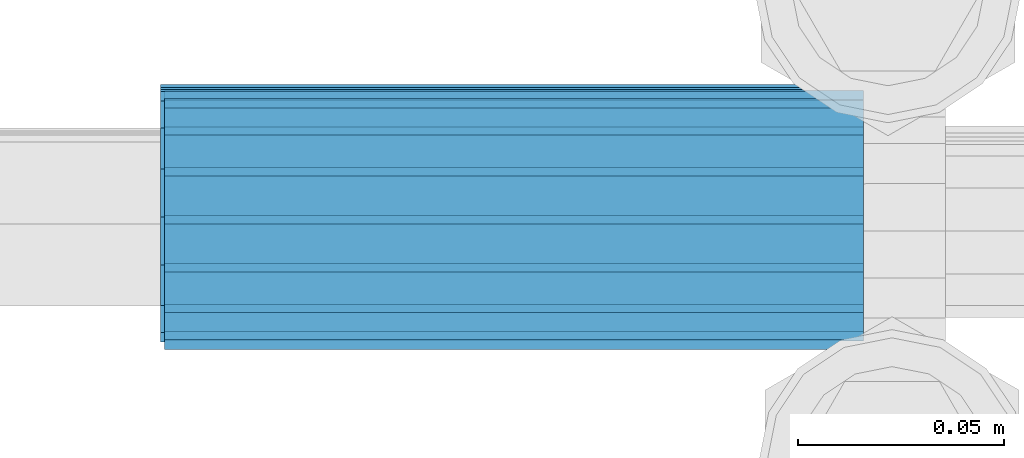
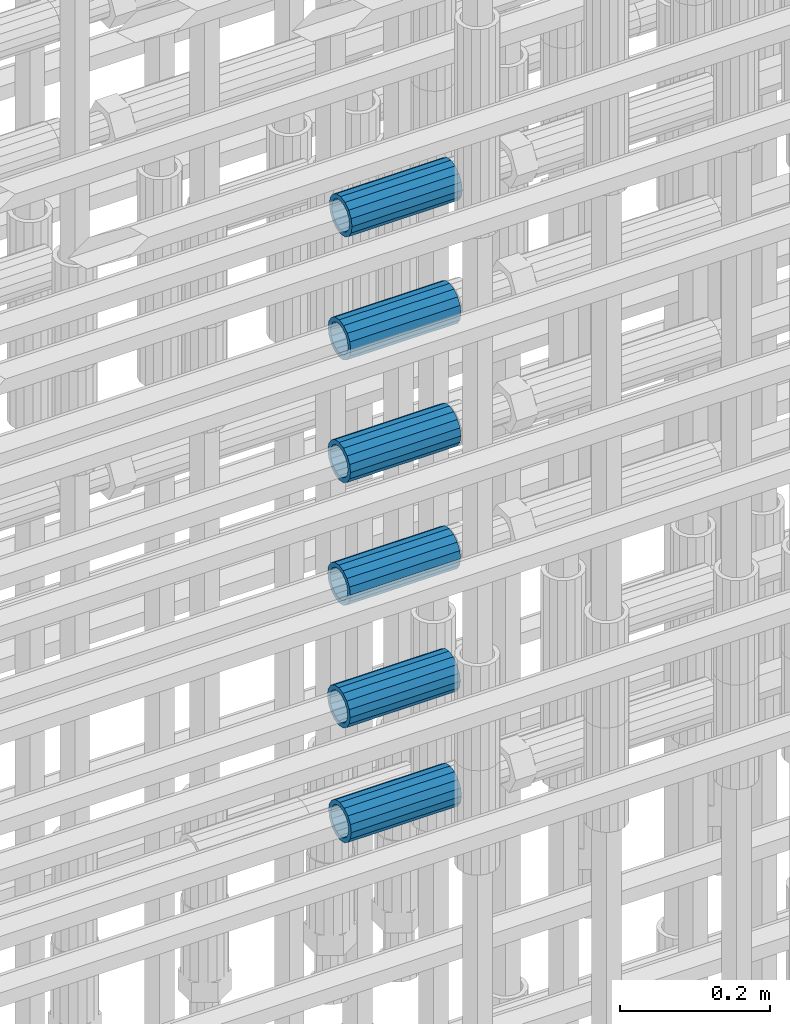
# One storey, part 25 of 119: 6 beams.
"""IFC2X3 building model written with IfcOpenShell, lengths in millimetres."""

import ifcopenshell
import ifcopenshell.guid

model = None  # the IFC model being written
_history = None  # IfcOwnerHistory: only IFC2X3 demands one
_inside = {}  # id of a spatial element -> (the spatial element, [elements in it])
_under = {}  # id of a project, library or spatial element -> (it, [spatial elements below it])
_declared = {}  # id of a project -> (the project, [libraries it declares])
_typed = {}  # id of a type object -> (the type object, [elements of that type])
_made_of = {}  # id of a material, layer set ... -> (it, [elements and type objects made of it])


def new_model(schema):
    """Start an empty IFC model of exactly this schema.

    Asked for "IFC4X3", IfcOpenShell would pick the latest addendum, in which some entities
    have other attributes; the version numbers below select the first issue.
    IFC2X3 requires an IfcOwnerHistory on every rooted entity: one is made here for all.
    """
    global model, _history
    if schema == "IFC4X3":
        model = ifcopenshell.file(schema_version=(4, 3, 0, 0))
    else:
        model = ifcopenshell.file(schema=schema)
    _inside.clear()
    _under.clear()
    _declared.clear()
    _typed.clear()
    _made_of.clear()
    _history = None
    if model.schema == "IFC2X3":
        org = make("IfcOrganization", Name="unknown")
        user = make(
            "IfcPersonAndOrganization",
            ThePerson=make("IfcPerson", FamilyName="unknown"),
            TheOrganization=org,
        )
        app = make(
            "IfcApplication",
            ApplicationDeveloper=org,
            Version="unknown",
            ApplicationFullName="unknown",
            ApplicationIdentifier="unknown",
        )
        _history = make(
            "IfcOwnerHistory",
            OwningUser=user,
            OwningApplication=app,
            ChangeAction="ADDED",
            CreationDate=0,
        )
    return model


def make(cls, **values):
    """One entity of the class cls with the attributes given. An attribute that is None is left unset."""
    return model.create_entity(
        cls, **{name: value for name, value in values.items() if value is not None}
    )


def rooted(cls, **values):
    """An entity with a GlobalId (a new one), such as an element, a storey or a relation."""
    return make(cls, GlobalId=ifcopenshell.guid.new(), OwnerHistory=_history, **values)


def si_unit(unit_type, name, prefix=None):
    """IfcSIUnit, for example si_unit("LENGTHUNIT", "METRE", prefix="MILLI")."""
    return make("IfcSIUnit", UnitType=unit_type, Prefix=prefix, Name=name)


def assignment(units):
    """IfcUnitAssignment: the units of a project."""
    return None if units is None else make("IfcUnitAssignment", Units=units)


def point(xyz):
    """IfcCartesianPoint."""
    return None if xyz is None else make("IfcCartesianPoint", Coordinates=xyz)


def direction(xyz):
    """IfcDirection."""
    return None if xyz is None else make("IfcDirection", DirectionRatios=xyz)


def frame(location, z_axis=None, x_axis=None):
    """IfcAxis2Placement3D, a coordinate frame: its origin and axes. An axis left out is left unset."""
    return make(
        "IfcAxis2Placement3D",
        Location=point(location),
        Axis=direction(z_axis),
        RefDirection=direction(x_axis),
    )


def origin_with_axes():
    """The frame at (0, 0, 0) with the z axis (0, 0, 1) and the x axis (1, 0, 0) written out."""
    return frame((0.0, 0.0, 0.0), z_axis=(0.0, 0.0, 1.0), x_axis=(1.0, 0.0, 0.0))


def place(relative_to, where):
    """IfcLocalPlacement: puts the frame where relative to a parent placement (None: the world)."""
    return make(
        "IfcLocalPlacement", PlacementRelTo=relative_to, RelativePlacement=where
    )


def context(
    kind, dimensions, precision=None, world=None, true_north=None, identifier=None
):
    """IfcGeometricRepresentationContext, for example the 3D "Model" context."""
    return make(
        "IfcGeometricRepresentationContext",
        ContextIdentifier=identifier,
        ContextType=kind,
        CoordinateSpaceDimension=dimensions,
        Precision=precision,
        WorldCoordinateSystem=world,
        TrueNorth=true_north,
    )


def subcontext(parent, identifier, kind, view, scale=None):
    """IfcGeometricRepresentationSubContext, for example "Body" below "Model"."""
    return make(
        "IfcGeometricRepresentationSubContext",
        ContextIdentifier=identifier,
        ContextType=kind,
        ParentContext=parent,
        TargetScale=scale,
        TargetView=view,
    )


def project(units=None, contexts=None):
    """IfcProject with its units and contexts."""
    return rooted(
        "IfcProject",
        Name="project",
        RepresentationContexts=contexts,
        UnitsInContext=assignment(units),
    )


def spatial(cls, under=None, at=None, **own):
    """A site, building, storey or space (cls), placed at a placement, below another one or the project."""
    s = rooted(cls, ObjectPlacement=at, **own)
    if under is not None:
        _under.setdefault(under.id(), (under, []))[1].append(s)
    return s


def faces_of(points, faces, orient=None, outer=None):
    """IfcFace entities. A face is a list of loops; a loop is a list of indices into points, from 0.

    orient and outer hold one flag for each loop. By default every Orientation is true, the
    first loop of a face is its IfcFaceOuterBound and the others are IfcFaceBound.
    """
    made = []
    for i, loops in enumerate(faces):
        bounds = []
        for j, loop in enumerate(loops):
            is_outer = j == 0 if outer is None else outer[i][j]
            bounds.append(
                make(
                    "IfcFaceOuterBound" if is_outer else "IfcFaceBound",
                    Bound=make("IfcPolyLoop", Polygon=[points[k] for k in loop]),
                    Orientation=True if orient is None else orient[i][j],
                )
            )
        made.append(make("IfcFace", Bounds=bounds))
    return made


def faceted_brep(points, faces, orient=None, outer=None, voids=None):
    """IfcFacetedBrep: a solid bounded by flat faces; with voids (closed shells), ...WithVoids."""
    shared = [point(p) for p in points]
    hull = make("IfcClosedShell", CfsFaces=faces_of(shared, faces, orient, outer))
    if voids is None:
        return make("IfcFacetedBrep", Outer=hull)
    return make(
        "IfcFacetedBrepWithVoids",
        Outer=hull,
        Voids=[
            make(cls, CfsFaces=faces_of(shared, fs, o, b)) for cls, fs, o, b in voids
        ],
    )


def shape(context_of_items, identifier, shape_type, items):
    """IfcShapeRepresentation: the items that make up one representation, for example the "Body"."""
    return make(
        "IfcShapeRepresentation",
        ContextOfItems=context_of_items,
        RepresentationIdentifier=identifier,
        RepresentationType=shape_type,
        Items=items,
    )


def material(Name=None, Category=None):
    """IfcMaterial."""
    return make("IfcMaterial", Name=Name, Category=Category)


def made_of(thing, what):
    """Note that an element or type object is made of a material, layer set ...; save() writes the relation."""
    if what is not None:
        _made_of.setdefault(what.id(), (what, []))[1].append(thing)
    return thing


def type_object(cls, material=None, **own):
    """A type object (cls), such as IfcWallType, which elements share."""
    return made_of(rooted(cls, **own), material)


def element(
    cls,
    number,
    at=None,
    inside=None,
    cuts=None,
    type_object=None,
    material=None,
    context=None,
    identifier="Body",
    shape_type=None,
    held_by="IfcProductDefinitionShape",
    body=None,
    shapes=None,
    **own,
):
    """One element of the class cls, such as IfcWall. Its Tag is "e" and its number.

    at: its placement. inside: the storey or other place that contains it. cuts: it is an
    opening in that element (IfcRelVoidsElement). A single representation is given by context,
    identifier, shape_type and body (its items); several are given by shapes. held_by: the class
    of the entity that holds the representations. save() writes the other relations.
    """
    e = rooted(cls, Tag="e%d" % number, ObjectPlacement=at, **own)
    if body is not None:
        shapes = [shape(context, identifier, shape_type, body)]
    if shapes is not None:
        e.Representation = make(held_by, Representations=shapes)
    if inside is not None:
        _inside.setdefault(inside.id(), (inside, []))[1].append(e)
    if cuts is not None:
        rooted(
            "IfcRelVoidsElement", RelatingBuildingElement=cuts, RelatedOpeningElement=e
        )
    if type_object is not None:
        _typed.setdefault(type_object.id(), (type_object, []))[1].append(e)
    return made_of(e, material)


def aggregate(whole, parts):
    """IfcRelAggregates: a whole, such as a stair, and the parts it consists of."""
    return rooted("IfcRelAggregates", RelatingObject=whole, RelatedObjects=parts)


def save(model, path):
    """Write the relations noted so far, then the file.

    IfcRelAggregates (storeys below a building ...), IfcRelContainedInSpatialStructure (elements
    in a storey), IfcRelDefinesByType, IfcRelAssociatesMaterial and IfcRelDeclares: one each for
    every whole, place, type object, material and project.
    """
    for whole, parts in _under.values():
        aggregate(whole, parts)
    for where, things in _inside.values():
        rooted(
            "IfcRelContainedInSpatialStructure",
            RelatedElements=things,
            RelatingStructure=where,
        )
    for kind, things in _typed.values():
        rooted("IfcRelDefinesByType", RelatedObjects=things, RelatingType=kind)
    for what, things in _made_of.values():
        rooted("IfcRelAssociatesMaterial", RelatedObjects=things, RelatingMaterial=what)
    for by, libraries in _declared.values():
        rooted("IfcRelDeclares", RelatingContext=by, RelatedDefinitions=libraries)
    model.write(path)


model = new_model("IFC2X3")

# Units and contexts
model_context = context("Model", 3, precision=1e-05, world=origin_with_axes())
body_context = subcontext(model_context, "Body", "Model", "MODEL_VIEW")
ifc_project = project(units=[si_unit("LENGTHUNIT", "METRE", prefix="MILLI"), si_unit("AREAUNIT", "SQUARE_METRE"), si_unit("VOLUMEUNIT", "CUBIC_METRE"), si_unit("MASSUNIT", "GRAM", prefix="KILO"), si_unit("TIMEUNIT", "SECOND"), si_unit("PLANEANGLEUNIT", "RADIAN"), si_unit("SOLIDANGLEUNIT", "STERADIAN"), si_unit("THERMODYNAMICTEMPERATUREUNIT", "DEGREE_CELSIUS"), si_unit("LUMINOUSINTENSITYUNIT", "LUMEN")], contexts=[model_context])

# Site, building, storey
site_placement = place(None, origin_with_axes())
site = spatial("IfcSite", under=ifc_project, at=site_placement, CompositionType="ELEMENT")
building_placement = place(site_placement, origin_with_axes())
building = spatial("IfcBuilding", under=site, at=building_placement, Name="Undefined", CompositionType="ELEMENT")
storey_placement = place(building_placement, origin_with_axes())
storey = spatial("IfcBuildingStorey", under=building, at=storey_placement, Name="Undefined", CompositionType="ELEMENT", Elevation=0.0)

# Beams
ifc_material = material(Name="STEEL/S275")
beam_type = type_object("IfcBeamType", PredefinedType="NOTDEFINED")
beam_1_placement = place(storey_placement, frame((2034949.03023304, 6205213.98994599, 19759.9894131571), z_axis=(0.0, 0.0, 1.0), x_axis=(1.0, 0.0, 0.0)))
element("IfcBeam", 1, at=beam_1_placement, inside=storey, type_object=beam_type, material=ifc_material, Name="AG40N", context=body_context, shape_type="Brep", body=[
    faceted_brep([(1.62981450557709e-09, -23.4999999990687, 0.0), (7.45058059692383e-09, -21.7111690142192, 8.99306066057534), (170.000002125278, -21.711168999318, 8.99306066022245), (170.000002127141, -23.4999999844003, -3.66071617463604e-10), (4.65661287307739e-09, -16.6170093587134, 16.6170093578889), (170.000002122484, -16.6170093440451, 16.6170093575288), (1.86264514923096e-09, -8.99306066217832, 21.7111690140277), (170.000002118759, -8.99306064750999, 21.7111690136603), (2.3283064365387e-10, 9.31322574615479e-10, 23.5), (170.000002114102, 1.28056854009628e-08, 23.4999999996485), (-6.51925802230835e-09, 8.99306065868586, 21.7111690140241), (170.00000211224, 8.99306067335419, 21.7111690136639), (-7.45058059692383e-09, 16.6170093561523, 16.6170093578853), (170.000002109446, 16.6170093708206, 16.6170093575324), (-9.31322574615479e-09, 21.711169013055, 8.99306066057534), (170.000002108514, 21.7111690277234, 8.99306066022245), (-1.16415321826935e-09, 23.5000000009313, 0.0), (170.000002108514, 23.5000000144355, -3.66071617463604e-10), (-8.38190317153931e-09, 21.7111690151505, -8.99306066059444), (170.000002110377, 21.7111690300517, -8.9930606609546), (-5.58793544769287e-09, 16.6170093598776, -16.6170093579008), (170.000002113171, 16.6170093745459, -16.6170093582609), (-9.31322574615479e-10, 8.99306066334248, -21.7111690140396), (170.000002115965, 8.99306067801081, -21.7111690143961), (2.3283064365387e-10, 9.31322574615479e-10, -23.5), (170.00000211969, 1.7927959561348e-08, -23.5000000003843), (5.58793544769287e-09, -8.99306065752171, -21.7111690140396), (170.000002123415, -8.99306064285338, -21.7111690143961), (8.38190317153931e-09, -16.6170093549881, -16.6170093579008), (170.000002125278, -16.6170093403198, -16.6170093582646), (9.31322574615479e-09, -21.7111690121237, -8.99306066059444), (170.000002127141, -21.7111689972226, -8.9930606609546), (1.11758708953857e-08, -30.4999999990687, -9.54969436861575e-12), (1.30385160446167e-08, -28.1783257392235, -11.6718446871514), (170.000002129003, -28.1783257243223, -11.6718446875116), (170.000002129935, -30.4999999841675, -3.66071617463604e-10), (1.02445483207703e-08, -21.5667568228673, -21.5667568262129), (170.000002128072, -21.566756808199, -21.5667568265694), (7.45058059692383e-09, -11.6718446831219, -28.1783257416196), (170.000002125278, -11.6718446684536, -28.1783257419834), (3.72529029846191e-09, 3.95812094211578e-09, -30.5000000000277), (170.00000211969, 1.83936208486557e-08, -30.5000000003879), (-9.31322574615479e-10, 11.6718446905725, -28.1783257416232), (170.000002115965, 11.6718447052408, -28.1783257419797), (-6.51925802230835e-09, 21.5667568286881, -21.5667568262093), (170.000002110377, 21.5667568433564, -21.5667568265694), (-9.31322574615479e-09, 28.178325742716, -11.6718446871478), (170.000002108514, 28.1783257573843, -11.6718446875079), (-1.21071934700012e-08, 30.5, -5.91171556152403e-12), (170.000002106652, 30.5000000144355, -3.62433638656512e-10), (-1.21071934700012e-08, 28.1783257401548, 11.6718446871359), (170.00000210572, 28.1783257548232, 11.6718446867794), (-1.02445483207703e-08, 21.5667568240315, 21.5667568261974), (170.000002107583, 21.566756838467, 21.5667568258409), (-7.45058059692383e-09, 11.671844684286, 28.1783257416041), (170.000002110377, 11.6718446989544, 28.178325741244), (-2.79396772384644e-09, -2.56113708019257e-09, 30.5000000000159), (170.000002114102, 1.18743628263474e-08, 30.4999999996558), (1.86264514923096e-09, -11.6718446896411, 28.1783257416114), (170.000002118759, -11.67184467474, 28.178325741244), (7.45058059692383e-09, -21.5667568275239, 21.5667568261974), (170.000002123415, -21.5667568126228, 21.5667568258373), (1.02445483207703e-08, -28.1783257415518, 11.6718446871359), (170.000002127141, -28.1783257271163, 11.6718446867794)], [[[0, 1, 2, 3]], [[1, 4, 5, 2]], [[4, 6, 7, 5]], [[6, 8, 9, 7]], [[8, 10, 11, 9]], [[10, 12, 13, 11]], [[12, 14, 15, 13]], [[14, 16, 17, 15]], [[16, 18, 19, 17]], [[18, 20, 21, 19]], [[20, 22, 23, 21]], [[22, 24, 25, 23]], [[24, 26, 27, 25]], [[26, 28, 29, 27]], [[28, 30, 31, 29]], [[30, 0, 3, 31]], [[32, 33, 34, 35]], [[33, 36, 37, 34]], [[36, 38, 39, 37]], [[38, 40, 41, 39]], [[40, 42, 43, 41]], [[42, 44, 45, 43]], [[44, 46, 47, 45]], [[46, 48, 49, 47]], [[48, 50, 51, 49]], [[50, 52, 53, 51]], [[52, 54, 55, 53]], [[54, 56, 57, 55]], [[56, 58, 59, 57]], [[58, 60, 61, 59]], [[60, 62, 63, 61]], [[62, 32, 35, 63]], [[37, 39, 41, 43, 45, 47, 49, 51, 53, 55, 57, 59, 61, 63, 35, 34], [5, 7, 9, 11, 13, 15, 17, 19, 21, 23, 25, 27, 29, 31, 3, 2]], [[62, 60, 58, 56, 54, 52, 50, 48, 46, 44, 42, 40, 38, 36, 33, 32], [30, 28, 26, 24, 22, 20, 18, 16, 14, 12, 10, 8, 6, 4, 1, 0]]]),
])
beam_2_placement = place(storey_placement, frame((2034948.03023304, 6205215.44994599, 19946.4594114617), z_axis=(0.0, 0.0, 1.0), x_axis=(1.0, 0.0, 0.0)))
element("IfcBeam", 2, at=beam_2_placement, inside=storey, type_object=beam_type, material=ifc_material, Name="AG40N", context=body_context, shape_type="Brep", body=[
    faceted_brep([(1.62981450557709e-09, -23.4999999990687, 0.0), (7.45058059692383e-09, -21.7111690142192, 8.99306066057534), (170.000002125278, -21.711168999318, 8.99306066022245), (170.000002127141, -23.4999999844003, -3.66071617463604e-10), (4.65661287307739e-09, -16.6170093587134, 16.6170093578889), (170.000002122484, -16.6170093440451, 16.6170093575288), (1.86264514923096e-09, -8.99306066217832, 21.7111690140277), (170.000002118759, -8.99306064750999, 21.7111690136603), (2.3283064365387e-10, 9.31322574615479e-10, 23.5), (170.000002114102, 1.28056854009628e-08, 23.4999999996485), (-6.51925802230835e-09, 8.99306065868586, 21.7111690140241), (170.00000211224, 8.99306067335419, 21.7111690136639), (-7.45058059692383e-09, 16.6170093561523, 16.6170093578853), (170.000002109446, 16.6170093708206, 16.6170093575324), (-9.31322574615479e-09, 21.711169013055, 8.99306066057534), (170.000002108514, 21.7111690277234, 8.99306066022245), (-1.16415321826935e-09, 23.5000000009313, 0.0), (170.000002108514, 23.5000000144355, -3.66071617463604e-10), (-8.38190317153931e-09, 21.7111690151505, -8.99306066059444), (170.000002110377, 21.7111690300517, -8.9930606609546), (-5.58793544769287e-09, 16.6170093598776, -16.6170093579008), (170.000002113171, 16.6170093745459, -16.6170093582609), (-9.31322574615479e-10, 8.99306066334248, -21.7111690140396), (170.000002115965, 8.99306067801081, -21.7111690143961), (2.3283064365387e-10, 9.31322574615479e-10, -23.5), (170.00000211969, 1.7927959561348e-08, -23.5000000003843), (5.58793544769287e-09, -8.99306065752171, -21.7111690140396), (170.000002123415, -8.99306064285338, -21.7111690143961), (8.38190317153931e-09, -16.6170093549881, -16.6170093579008), (170.000002125278, -16.6170093403198, -16.6170093582646), (9.31322574615479e-09, -21.7111690121237, -8.99306066059444), (170.000002127141, -21.7111689972226, -8.9930606609546), (1.11758708953857e-08, -30.4999999990687, -9.54969436861575e-12), (1.30385160446167e-08, -28.1783257392235, -11.6718446871514), (170.000002129003, -28.1783257243223, -11.6718446875116), (170.000002129935, -30.4999999841675, -3.66071617463604e-10), (1.02445483207703e-08, -21.5667568228673, -21.5667568262129), (170.000002128072, -21.566756808199, -21.5667568265694), (7.45058059692383e-09, -11.6718446831219, -28.1783257416196), (170.000002125278, -11.6718446684536, -28.1783257419834), (3.72529029846191e-09, 3.95812094211578e-09, -30.5000000000277), (170.00000211969, 1.83936208486557e-08, -30.5000000003879), (-9.31322574615479e-10, 11.6718446905725, -28.1783257416232), (170.000002115965, 11.6718447052408, -28.1783257419797), (-6.51925802230835e-09, 21.5667568286881, -21.5667568262093), (170.000002110377, 21.5667568433564, -21.5667568265694), (-9.31322574615479e-09, 28.178325742716, -11.6718446871478), (170.000002108514, 28.1783257573843, -11.6718446875079), (-1.21071934700012e-08, 30.5, -5.91171556152403e-12), (170.000002106652, 30.5000000144355, -3.62433638656512e-10), (-1.21071934700012e-08, 28.1783257401548, 11.6718446871359), (170.00000210572, 28.1783257548232, 11.6718446867794), (-1.02445483207703e-08, 21.5667568240315, 21.5667568261974), (170.000002107583, 21.566756838467, 21.5667568258409), (-7.45058059692383e-09, 11.671844684286, 28.1783257416041), (170.000002110377, 11.6718446989544, 28.178325741244), (-2.79396772384644e-09, -2.56113708019257e-09, 30.5000000000159), (170.000002114102, 1.18743628263474e-08, 30.4999999996558), (1.86264514923096e-09, -11.6718446896411, 28.1783257416114), (170.000002118759, -11.67184467474, 28.178325741244), (7.45058059692383e-09, -21.5667568275239, 21.5667568261974), (170.000002123415, -21.5667568126228, 21.5667568258373), (1.02445483207703e-08, -28.1783257415518, 11.6718446871359), (170.000002127141, -28.1783257271163, 11.6718446867794)], [[[0, 1, 2, 3]], [[1, 4, 5, 2]], [[4, 6, 7, 5]], [[6, 8, 9, 7]], [[8, 10, 11, 9]], [[10, 12, 13, 11]], [[12, 14, 15, 13]], [[14, 16, 17, 15]], [[16, 18, 19, 17]], [[18, 20, 21, 19]], [[20, 22, 23, 21]], [[22, 24, 25, 23]], [[24, 26, 27, 25]], [[26, 28, 29, 27]], [[28, 30, 31, 29]], [[30, 0, 3, 31]], [[32, 33, 34, 35]], [[33, 36, 37, 34]], [[36, 38, 39, 37]], [[38, 40, 41, 39]], [[40, 42, 43, 41]], [[42, 44, 45, 43]], [[44, 46, 47, 45]], [[46, 48, 49, 47]], [[48, 50, 51, 49]], [[50, 52, 53, 51]], [[52, 54, 55, 53]], [[54, 56, 57, 55]], [[56, 58, 59, 57]], [[58, 60, 61, 59]], [[60, 62, 63, 61]], [[62, 32, 35, 63]], [[37, 39, 41, 43, 45, 47, 49, 51, 53, 55, 57, 59, 61, 63, 35, 34], [5, 7, 9, 11, 13, 15, 17, 19, 21, 23, 25, 27, 29, 31, 3, 2]], [[62, 60, 58, 56, 54, 52, 50, 48, 46, 44, 42, 40, 38, 36, 33, 32], [30, 28, 26, 24, 22, 20, 18, 16, 14, 12, 10, 8, 6, 4, 1, 0]]]),
])
beam_3_placement = place(storey_placement, frame((2034948.03023304, 6205214.71994599, 20146.4594115062), z_axis=(0.0, 0.0, 1.0), x_axis=(1.0, 0.0, 0.0)))
element("IfcBeam", 3, at=beam_3_placement, inside=storey, type_object=beam_type, material=ifc_material, Name="AG40N", context=body_context, shape_type="Brep", body=[
    faceted_brep([(1.62981450557709e-09, -23.4999999990687, 0.0), (7.45058059692383e-09, -21.7111690142192, 8.99306066057534), (170.000002125278, -21.711168999318, 8.99306066022245), (170.000002127141, -23.4999999844003, -3.66071617463604e-10), (4.65661287307739e-09, -16.6170093587134, 16.6170093578889), (170.000002122484, -16.6170093440451, 16.6170093575288), (1.86264514923096e-09, -8.99306066217832, 21.7111690140277), (170.000002118759, -8.99306064750999, 21.7111690136603), (2.3283064365387e-10, 9.31322574615479e-10, 23.5), (170.000002114102, 1.28056854009628e-08, 23.4999999996485), (-6.51925802230835e-09, 8.99306065868586, 21.7111690140241), (170.00000211224, 8.99306067335419, 21.7111690136639), (-7.45058059692383e-09, 16.6170093561523, 16.6170093578853), (170.000002109446, 16.6170093708206, 16.6170093575324), (-9.31322574615479e-09, 21.711169013055, 8.99306066057534), (170.000002108514, 21.7111690277234, 8.99306066022245), (-1.16415321826935e-09, 23.5000000009313, 0.0), (170.000002108514, 23.5000000144355, -3.66071617463604e-10), (-8.38190317153931e-09, 21.7111690151505, -8.99306066059444), (170.000002110377, 21.7111690300517, -8.9930606609546), (-5.58793544769287e-09, 16.6170093598776, -16.6170093579008), (170.000002113171, 16.6170093745459, -16.6170093582609), (-9.31322574615479e-10, 8.99306066334248, -21.7111690140396), (170.000002115965, 8.99306067801081, -21.7111690143961), (2.3283064365387e-10, 9.31322574615479e-10, -23.5), (170.00000211969, 1.7927959561348e-08, -23.5000000003843), (5.58793544769287e-09, -8.99306065752171, -21.7111690140396), (170.000002123415, -8.99306064285338, -21.7111690143961), (8.38190317153931e-09, -16.6170093549881, -16.6170093579008), (170.000002125278, -16.6170093403198, -16.6170093582646), (9.31322574615479e-09, -21.7111690121237, -8.99306066059444), (170.000002127141, -21.7111689972226, -8.9930606609546), (1.11758708953857e-08, -30.4999999990687, -9.54969436861575e-12), (1.30385160446167e-08, -28.1783257392235, -11.6718446871514), (170.000002129003, -28.1783257243223, -11.6718446875116), (170.000002129935, -30.4999999841675, -3.66071617463604e-10), (1.02445483207703e-08, -21.5667568228673, -21.5667568262129), (170.000002128072, -21.566756808199, -21.5667568265694), (7.45058059692383e-09, -11.6718446831219, -28.1783257416196), (170.000002125278, -11.6718446684536, -28.1783257419834), (3.72529029846191e-09, 3.95812094211578e-09, -30.5000000000277), (170.00000211969, 1.83936208486557e-08, -30.5000000003879), (-9.31322574615479e-10, 11.6718446905725, -28.1783257416232), (170.000002115965, 11.6718447052408, -28.1783257419797), (-6.51925802230835e-09, 21.5667568286881, -21.5667568262093), (170.000002110377, 21.5667568433564, -21.5667568265694), (-9.31322574615479e-09, 28.178325742716, -11.6718446871478), (170.000002108514, 28.1783257573843, -11.6718446875079), (-1.21071934700012e-08, 30.5, -5.91171556152403e-12), (170.000002106652, 30.5000000144355, -3.62433638656512e-10), (-1.21071934700012e-08, 28.1783257401548, 11.6718446871359), (170.00000210572, 28.1783257548232, 11.6718446867794), (-1.02445483207703e-08, 21.5667568240315, 21.5667568261974), (170.000002107583, 21.566756838467, 21.5667568258409), (-7.45058059692383e-09, 11.671844684286, 28.1783257416041), (170.000002110377, 11.6718446989544, 28.178325741244), (-2.79396772384644e-09, -2.56113708019257e-09, 30.5000000000159), (170.000002114102, 1.18743628263474e-08, 30.4999999996558), (1.86264514923096e-09, -11.6718446896411, 28.1783257416114), (170.000002118759, -11.67184467474, 28.178325741244), (7.45058059692383e-09, -21.5667568275239, 21.5667568261974), (170.000002123415, -21.5667568126228, 21.5667568258373), (1.02445483207703e-08, -28.1783257415518, 11.6718446871359), (170.000002127141, -28.1783257271163, 11.6718446867794)], [[[0, 1, 2, 3]], [[1, 4, 5, 2]], [[4, 6, 7, 5]], [[6, 8, 9, 7]], [[8, 10, 11, 9]], [[10, 12, 13, 11]], [[12, 14, 15, 13]], [[14, 16, 17, 15]], [[16, 18, 19, 17]], [[18, 20, 21, 19]], [[20, 22, 23, 21]], [[22, 24, 25, 23]], [[24, 26, 27, 25]], [[26, 28, 29, 27]], [[28, 30, 31, 29]], [[30, 0, 3, 31]], [[32, 33, 34, 35]], [[33, 36, 37, 34]], [[36, 38, 39, 37]], [[38, 40, 41, 39]], [[40, 42, 43, 41]], [[42, 44, 45, 43]], [[44, 46, 47, 45]], [[46, 48, 49, 47]], [[48, 50, 51, 49]], [[50, 52, 53, 51]], [[52, 54, 55, 53]], [[54, 56, 57, 55]], [[56, 58, 59, 57]], [[58, 60, 61, 59]], [[60, 62, 63, 61]], [[62, 32, 35, 63]], [[37, 39, 41, 43, 45, 47, 49, 51, 53, 55, 57, 59, 61, 63, 35, 34], [5, 7, 9, 11, 13, 15, 17, 19, 21, 23, 25, 27, 29, 31, 3, 2]], [[62, 60, 58, 56, 54, 52, 50, 48, 46, 44, 42, 40, 38, 36, 33, 32], [30, 28, 26, 24, 22, 20, 18, 16, 14, 12, 10, 8, 6, 4, 1, 0]]]),
])
beam_4_placement = place(storey_placement, frame((2034948.03023304, 6205214.21994599, 20346.4694114171), z_axis=(0.0, 0.0, 1.0), x_axis=(1.0, 0.0, 0.0)))
element("IfcBeam", 4, at=beam_4_placement, inside=storey, type_object=beam_type, material=ifc_material, Name="AG40N", context=body_context, shape_type="Brep", body=[
    faceted_brep([(1.62981450557709e-09, -23.4999999990687, 0.0), (7.45058059692383e-09, -21.7111690142192, 8.99306066057534), (170.000002125278, -21.711168999318, 8.99306066022245), (170.000002127141, -23.4999999844003, -3.66071617463604e-10), (4.65661287307739e-09, -16.6170093587134, 16.6170093578889), (170.000002122484, -16.6170093440451, 16.6170093575288), (1.86264514923096e-09, -8.99306066217832, 21.7111690140277), (170.000002118759, -8.99306064750999, 21.7111690136603), (2.3283064365387e-10, 9.31322574615479e-10, 23.5), (170.000002114102, 1.28056854009628e-08, 23.4999999996485), (-6.51925802230835e-09, 8.99306065868586, 21.7111690140241), (170.00000211224, 8.99306067335419, 21.7111690136639), (-7.45058059692383e-09, 16.6170093561523, 16.6170093578853), (170.000002109446, 16.6170093708206, 16.6170093575324), (-9.31322574615479e-09, 21.711169013055, 8.99306066057534), (170.000002108514, 21.7111690277234, 8.99306066022245), (-1.16415321826935e-09, 23.5000000009313, 0.0), (170.000002108514, 23.5000000144355, -3.66071617463604e-10), (-8.38190317153931e-09, 21.7111690151505, -8.99306066059444), (170.000002110377, 21.7111690300517, -8.9930606609546), (-5.58793544769287e-09, 16.6170093598776, -16.6170093579008), (170.000002113171, 16.6170093745459, -16.6170093582609), (-9.31322574615479e-10, 8.99306066334248, -21.7111690140396), (170.000002115965, 8.99306067801081, -21.7111690143961), (2.3283064365387e-10, 9.31322574615479e-10, -23.5), (170.00000211969, 1.7927959561348e-08, -23.5000000003843), (5.58793544769287e-09, -8.99306065752171, -21.7111690140396), (170.000002123415, -8.99306064285338, -21.7111690143961), (8.38190317153931e-09, -16.6170093549881, -16.6170093579008), (170.000002125278, -16.6170093403198, -16.6170093582646), (9.31322574615479e-09, -21.7111690121237, -8.99306066059444), (170.000002127141, -21.7111689972226, -8.9930606609546), (1.11758708953857e-08, -30.4999999990687, -9.54969436861575e-12), (1.30385160446167e-08, -28.1783257392235, -11.6718446871514), (170.000002129003, -28.1783257243223, -11.6718446875116), (170.000002129935, -30.4999999841675, -3.66071617463604e-10), (1.02445483207703e-08, -21.5667568228673, -21.5667568262129), (170.000002128072, -21.566756808199, -21.5667568265694), (7.45058059692383e-09, -11.6718446831219, -28.1783257416196), (170.000002125278, -11.6718446684536, -28.1783257419834), (3.72529029846191e-09, 3.95812094211578e-09, -30.5000000000277), (170.00000211969, 1.83936208486557e-08, -30.5000000003879), (-9.31322574615479e-10, 11.6718446905725, -28.1783257416232), (170.000002115965, 11.6718447052408, -28.1783257419797), (-6.51925802230835e-09, 21.5667568286881, -21.5667568262093), (170.000002110377, 21.5667568433564, -21.5667568265694), (-9.31322574615479e-09, 28.178325742716, -11.6718446871478), (170.000002108514, 28.1783257573843, -11.6718446875079), (-1.21071934700012e-08, 30.5, -5.91171556152403e-12), (170.000002106652, 30.5000000144355, -3.62433638656512e-10), (-1.21071934700012e-08, 28.1783257401548, 11.6718446871359), (170.00000210572, 28.1783257548232, 11.6718446867794), (-1.02445483207703e-08, 21.5667568240315, 21.5667568261974), (170.000002107583, 21.566756838467, 21.5667568258409), (-7.45058059692383e-09, 11.671844684286, 28.1783257416041), (170.000002110377, 11.6718446989544, 28.178325741244), (-2.79396772384644e-09, -2.56113708019257e-09, 30.5000000000159), (170.000002114102, 1.18743628263474e-08, 30.4999999996558), (1.86264514923096e-09, -11.6718446896411, 28.1783257416114), (170.000002118759, -11.67184467474, 28.178325741244), (7.45058059692383e-09, -21.5667568275239, 21.5667568261974), (170.000002123415, -21.5667568126228, 21.5667568258373), (1.02445483207703e-08, -28.1783257415518, 11.6718446871359), (170.000002127141, -28.1783257271163, 11.6718446867794)], [[[0, 1, 2, 3]], [[1, 4, 5, 2]], [[4, 6, 7, 5]], [[6, 8, 9, 7]], [[8, 10, 11, 9]], [[10, 12, 13, 11]], [[12, 14, 15, 13]], [[14, 16, 17, 15]], [[16, 18, 19, 17]], [[18, 20, 21, 19]], [[20, 22, 23, 21]], [[22, 24, 25, 23]], [[24, 26, 27, 25]], [[26, 28, 29, 27]], [[28, 30, 31, 29]], [[30, 0, 3, 31]], [[32, 33, 34, 35]], [[33, 36, 37, 34]], [[36, 38, 39, 37]], [[38, 40, 41, 39]], [[40, 42, 43, 41]], [[42, 44, 45, 43]], [[44, 46, 47, 45]], [[46, 48, 49, 47]], [[48, 50, 51, 49]], [[50, 52, 53, 51]], [[52, 54, 55, 53]], [[54, 56, 57, 55]], [[56, 58, 59, 57]], [[58, 60, 61, 59]], [[60, 62, 63, 61]], [[62, 32, 35, 63]], [[37, 39, 41, 43, 45, 47, 49, 51, 53, 55, 57, 59, 61, 63, 35, 34], [5, 7, 9, 11, 13, 15, 17, 19, 21, 23, 25, 27, 29, 31, 3, 2]], [[62, 60, 58, 56, 54, 52, 50, 48, 46, 44, 42, 40, 38, 36, 33, 32], [30, 28, 26, 24, 22, 20, 18, 16, 14, 12, 10, 8, 6, 4, 1, 0]]]),
])
beam_5_placement = place(storey_placement, frame((2034948.03023304, 6205213.71994599, 20546.4594114171), z_axis=(0.0, 0.0, 1.0), x_axis=(1.0, 0.0, 0.0)))
element("IfcBeam", 5, at=beam_5_placement, inside=storey, type_object=beam_type, material=ifc_material, Name="AG40N", context=body_context, shape_type="Brep", body=[
    faceted_brep([(1.62981450557709e-09, -23.4999999990687, 0.0), (7.45058059692383e-09, -21.7111690142192, 8.99306066057534), (170.000002125278, -21.711168999318, 8.99306066022245), (170.000002127141, -23.4999999844003, -3.66071617463604e-10), (4.65661287307739e-09, -16.6170093587134, 16.6170093578889), (170.000002122484, -16.6170093440451, 16.6170093575288), (1.86264514923096e-09, -8.99306066217832, 21.7111690140277), (170.000002118759, -8.99306064750999, 21.7111690136603), (2.3283064365387e-10, 9.31322574615479e-10, 23.5), (170.000002114102, 1.28056854009628e-08, 23.4999999996485), (-6.51925802230835e-09, 8.99306065868586, 21.7111690140241), (170.00000211224, 8.99306067335419, 21.7111690136639), (-7.45058059692383e-09, 16.6170093561523, 16.6170093578853), (170.000002109446, 16.6170093708206, 16.6170093575324), (-9.31322574615479e-09, 21.711169013055, 8.99306066057534), (170.000002108514, 21.7111690277234, 8.99306066022245), (-1.16415321826935e-09, 23.5000000009313, 0.0), (170.000002108514, 23.5000000144355, -3.66071617463604e-10), (-8.38190317153931e-09, 21.7111690151505, -8.99306066059444), (170.000002110377, 21.7111690300517, -8.9930606609546), (-5.58793544769287e-09, 16.6170093598776, -16.6170093579008), (170.000002113171, 16.6170093745459, -16.6170093582609), (-9.31322574615479e-10, 8.99306066334248, -21.7111690140396), (170.000002115965, 8.99306067801081, -21.7111690143961), (2.3283064365387e-10, 9.31322574615479e-10, -23.5), (170.00000211969, 1.7927959561348e-08, -23.5000000003843), (5.58793544769287e-09, -8.99306065752171, -21.7111690140396), (170.000002123415, -8.99306064285338, -21.7111690143961), (8.38190317153931e-09, -16.6170093549881, -16.6170093579008), (170.000002125278, -16.6170093403198, -16.6170093582646), (9.31322574615479e-09, -21.7111690121237, -8.99306066059444), (170.000002127141, -21.7111689972226, -8.9930606609546), (1.11758708953857e-08, -30.4999999990687, -9.54969436861575e-12), (1.30385160446167e-08, -28.1783257392235, -11.6718446871514), (170.000002129003, -28.1783257243223, -11.6718446875116), (170.000002129935, -30.4999999841675, -3.66071617463604e-10), (1.02445483207703e-08, -21.5667568228673, -21.5667568262129), (170.000002128072, -21.566756808199, -21.5667568265694), (7.45058059692383e-09, -11.6718446831219, -28.1783257416196), (170.000002125278, -11.6718446684536, -28.1783257419834), (3.72529029846191e-09, 3.95812094211578e-09, -30.5000000000277), (170.00000211969, 1.83936208486557e-08, -30.5000000003879), (-9.31322574615479e-10, 11.6718446905725, -28.1783257416232), (170.000002115965, 11.6718447052408, -28.1783257419797), (-6.51925802230835e-09, 21.5667568286881, -21.5667568262093), (170.000002110377, 21.5667568433564, -21.5667568265694), (-9.31322574615479e-09, 28.178325742716, -11.6718446871478), (170.000002108514, 28.1783257573843, -11.6718446875079), (-1.21071934700012e-08, 30.5, -5.91171556152403e-12), (170.000002106652, 30.5000000144355, -3.62433638656512e-10), (-1.21071934700012e-08, 28.1783257401548, 11.6718446871359), (170.00000210572, 28.1783257548232, 11.6718446867794), (-1.02445483207703e-08, 21.5667568240315, 21.5667568261974), (170.000002107583, 21.566756838467, 21.5667568258409), (-7.45058059692383e-09, 11.671844684286, 28.1783257416041), (170.000002110377, 11.6718446989544, 28.178325741244), (-2.79396772384644e-09, -2.56113708019257e-09, 30.5000000000159), (170.000002114102, 1.18743628263474e-08, 30.4999999996558), (1.86264514923096e-09, -11.6718446896411, 28.1783257416114), (170.000002118759, -11.67184467474, 28.178325741244), (7.45058059692383e-09, -21.5667568275239, 21.5667568261974), (170.000002123415, -21.5667568126228, 21.5667568258373), (1.02445483207703e-08, -28.1783257415518, 11.6718446871359), (170.000002127141, -28.1783257271163, 11.6718446867794)], [[[0, 1, 2, 3]], [[1, 4, 5, 2]], [[4, 6, 7, 5]], [[6, 8, 9, 7]], [[8, 10, 11, 9]], [[10, 12, 13, 11]], [[12, 14, 15, 13]], [[14, 16, 17, 15]], [[16, 18, 19, 17]], [[18, 20, 21, 19]], [[20, 22, 23, 21]], [[22, 24, 25, 23]], [[24, 26, 27, 25]], [[26, 28, 29, 27]], [[28, 30, 31, 29]], [[30, 0, 3, 31]], [[32, 33, 34, 35]], [[33, 36, 37, 34]], [[36, 38, 39, 37]], [[38, 40, 41, 39]], [[40, 42, 43, 41]], [[42, 44, 45, 43]], [[44, 46, 47, 45]], [[46, 48, 49, 47]], [[48, 50, 51, 49]], [[50, 52, 53, 51]], [[52, 54, 55, 53]], [[54, 56, 57, 55]], [[56, 58, 59, 57]], [[58, 60, 61, 59]], [[60, 62, 63, 61]], [[62, 32, 35, 63]], [[37, 39, 41, 43, 45, 47, 49, 51, 53, 55, 57, 59, 61, 63, 35, 34], [5, 7, 9, 11, 13, 15, 17, 19, 21, 23, 25, 27, 29, 31, 3, 2]], [[62, 60, 58, 56, 54, 52, 50, 48, 46, 44, 42, 40, 38, 36, 33, 32], [30, 28, 26, 24, 22, 20, 18, 16, 14, 12, 10, 8, 6, 4, 1, 0]]]),
])
beam_6_placement = place(storey_placement, frame((2034949.03023304, 6205211.99994599, 20747.8194114023), z_axis=(0.0, 0.0, 1.0), x_axis=(1.0, 0.0, 0.0)))
element("IfcBeam", 6, at=beam_6_placement, inside=storey, type_object=beam_type, material=ifc_material, Name="AG40N", context=body_context, shape_type="Brep", body=[
    faceted_brep([(1.62981450557709e-09, -23.4999999990687, 0.0), (7.45058059692383e-09, -21.7111690142192, 8.99306066057534), (170.000002125278, -21.711168999318, 8.99306066022245), (170.000002127141, -23.4999999844003, -3.66071617463604e-10), (4.65661287307739e-09, -16.6170093587134, 16.6170093578889), (170.000002122484, -16.6170093440451, 16.6170093575288), (1.86264514923096e-09, -8.99306066217832, 21.7111690140277), (170.000002118759, -8.99306064750999, 21.7111690136603), (2.3283064365387e-10, 9.31322574615479e-10, 23.5), (170.000002114102, 1.28056854009628e-08, 23.4999999996485), (-6.51925802230835e-09, 8.99306065868586, 21.7111690140241), (170.00000211224, 8.99306067335419, 21.7111690136639), (-7.45058059692383e-09, 16.6170093561523, 16.6170093578853), (170.000002109446, 16.6170093708206, 16.6170093575324), (-9.31322574615479e-09, 21.711169013055, 8.99306066057534), (170.000002108514, 21.7111690277234, 8.99306066022245), (-1.16415321826935e-09, 23.5000000009313, 0.0), (170.000002108514, 23.5000000144355, -3.66071617463604e-10), (-8.38190317153931e-09, 21.7111690151505, -8.99306066059444), (170.000002110377, 21.7111690300517, -8.9930606609546), (-5.58793544769287e-09, 16.6170093598776, -16.6170093579008), (170.000002113171, 16.6170093745459, -16.6170093582609), (-9.31322574615479e-10, 8.99306066334248, -21.7111690140396), (170.000002115965, 8.99306067801081, -21.7111690143961), (2.3283064365387e-10, 9.31322574615479e-10, -23.5), (170.00000211969, 1.7927959561348e-08, -23.5000000003843), (5.58793544769287e-09, -8.99306065752171, -21.7111690140396), (170.000002123415, -8.99306064285338, -21.7111690143961), (8.38190317153931e-09, -16.6170093549881, -16.6170093579008), (170.000002125278, -16.6170093403198, -16.6170093582646), (9.31322574615479e-09, -21.7111690121237, -8.99306066059444), (170.000002127141, -21.7111689972226, -8.9930606609546), (1.11758708953857e-08, -30.4999999990687, -9.54969436861575e-12), (1.30385160446167e-08, -28.1783257392235, -11.6718446871514), (170.000002129003, -28.1783257243223, -11.6718446875116), (170.000002129935, -30.4999999841675, -3.66071617463604e-10), (1.02445483207703e-08, -21.5667568228673, -21.5667568262129), (170.000002128072, -21.566756808199, -21.5667568265694), (7.45058059692383e-09, -11.6718446831219, -28.1783257416196), (170.000002125278, -11.6718446684536, -28.1783257419834), (3.72529029846191e-09, 3.95812094211578e-09, -30.5000000000277), (170.00000211969, 1.83936208486557e-08, -30.5000000003879), (-9.31322574615479e-10, 11.6718446905725, -28.1783257416232), (170.000002115965, 11.6718447052408, -28.1783257419797), (-6.51925802230835e-09, 21.5667568286881, -21.5667568262093), (170.000002110377, 21.5667568433564, -21.5667568265694), (-9.31322574615479e-09, 28.178325742716, -11.6718446871478), (170.000002108514, 28.1783257573843, -11.6718446875079), (-1.21071934700012e-08, 30.5, -5.91171556152403e-12), (170.000002106652, 30.5000000144355, -3.62433638656512e-10), (-1.21071934700012e-08, 28.1783257401548, 11.6718446871359), (170.00000210572, 28.1783257548232, 11.6718446867794), (-1.02445483207703e-08, 21.5667568240315, 21.5667568261974), (170.000002107583, 21.566756838467, 21.5667568258409), (-7.45058059692383e-09, 11.671844684286, 28.1783257416041), (170.000002110377, 11.6718446989544, 28.178325741244), (-2.79396772384644e-09, -2.56113708019257e-09, 30.5000000000159), (170.000002114102, 1.18743628263474e-08, 30.4999999996558), (1.86264514923096e-09, -11.6718446896411, 28.1783257416114), (170.000002118759, -11.67184467474, 28.178325741244), (7.45058059692383e-09, -21.5667568275239, 21.5667568261974), (170.000002123415, -21.5667568126228, 21.5667568258373), (1.02445483207703e-08, -28.1783257415518, 11.6718446871359), (170.000002127141, -28.1783257271163, 11.6718446867794)], [[[0, 1, 2, 3]], [[1, 4, 5, 2]], [[4, 6, 7, 5]], [[6, 8, 9, 7]], [[8, 10, 11, 9]], [[10, 12, 13, 11]], [[12, 14, 15, 13]], [[14, 16, 17, 15]], [[16, 18, 19, 17]], [[18, 20, 21, 19]], [[20, 22, 23, 21]], [[22, 24, 25, 23]], [[24, 26, 27, 25]], [[26, 28, 29, 27]], [[28, 30, 31, 29]], [[30, 0, 3, 31]], [[32, 33, 34, 35]], [[33, 36, 37, 34]], [[36, 38, 39, 37]], [[38, 40, 41, 39]], [[40, 42, 43, 41]], [[42, 44, 45, 43]], [[44, 46, 47, 45]], [[46, 48, 49, 47]], [[48, 50, 51, 49]], [[50, 52, 53, 51]], [[52, 54, 55, 53]], [[54, 56, 57, 55]], [[56, 58, 59, 57]], [[58, 60, 61, 59]], [[60, 62, 63, 61]], [[62, 32, 35, 63]], [[37, 39, 41, 43, 45, 47, 49, 51, 53, 55, 57, 59, 61, 63, 35, 34], [5, 7, 9, 11, 13, 15, 17, 19, 21, 23, 25, 27, 29, 31, 3, 2]], [[62, 60, 58, 56, 54, 52, 50, 48, 46, 44, 42, 40, 38, 36, 33, 32], [30, 28, 26, 24, 22, 20, 18, 16, 14, 12, 10, 8, 6, 4, 1, 0]]]),
])

save(model, "model.ifc")
